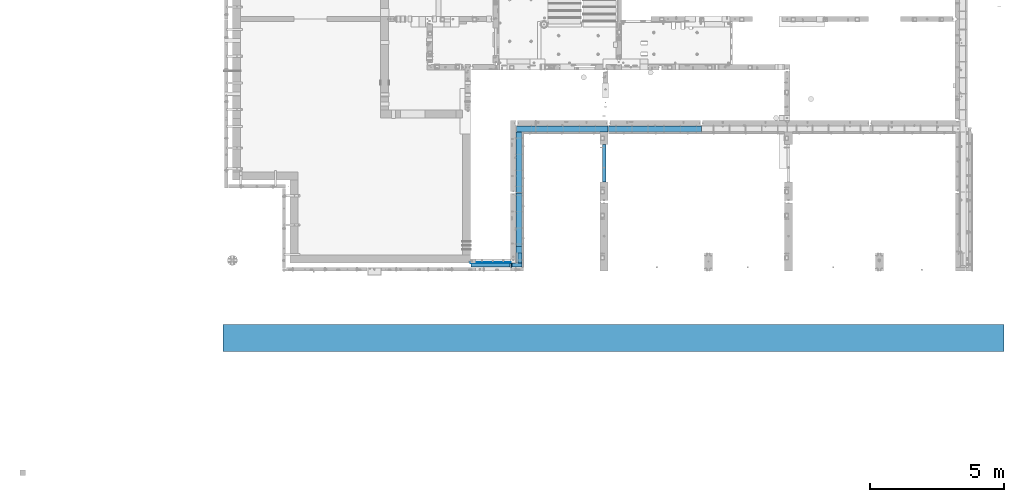
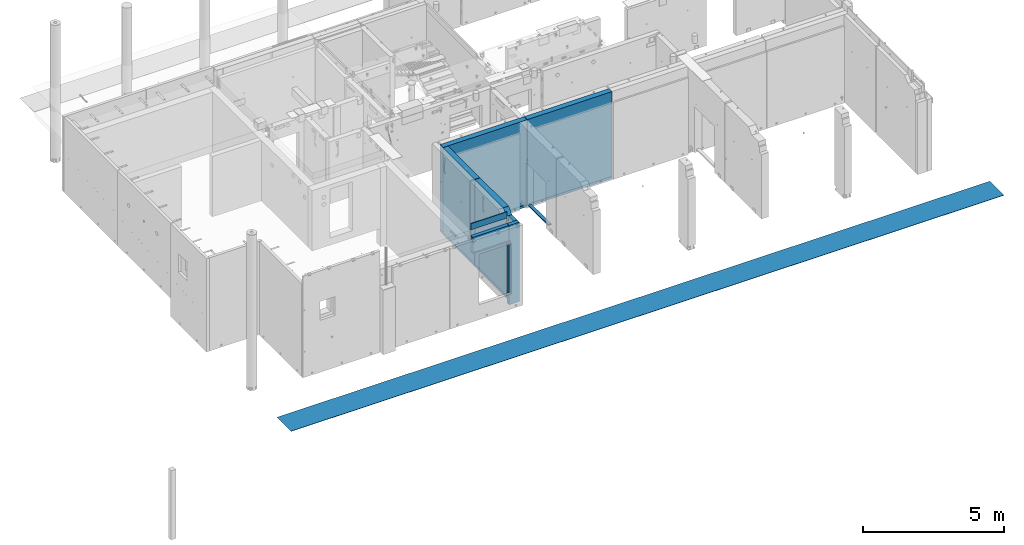
# One storey, part 79 of 264: 16 beams, 11 elements without a shape of their own.
"""IFC2X3 building model written with IfcOpenShell, lengths in millimetres."""

from ifc_helpers import new_model, si_unit, frame, origin_with_axes, place, context, subcontext, project, spatial, faceted_brep, material, type_object, element, aggregate, save


model = new_model("IFC2X3")

# Units and contexts
model_context = context("Model", 3, precision=1e-05, world=origin_with_axes())
body_context = subcontext(model_context, "Body", "Model", "MODEL_VIEW")
ifc_project = project(units=[si_unit("LENGTHUNIT", "METRE", prefix="MILLI"), si_unit("AREAUNIT", "SQUARE_METRE"), si_unit("VOLUMEUNIT", "CUBIC_METRE"), si_unit("MASSUNIT", "GRAM", prefix="KILO"), si_unit("TIMEUNIT", "SECOND"), si_unit("PLANEANGLEUNIT", "RADIAN"), si_unit("SOLIDANGLEUNIT", "STERADIAN"), si_unit("THERMODYNAMICTEMPERATUREUNIT", "DEGREE_CELSIUS"), si_unit("LUMINOUSINTENSITYUNIT", "LUMEN")], contexts=[model_context])

# Site, building, storey
site_placement = place(None, origin_with_axes())
site = spatial("IfcSite", under=ifc_project, at=site_placement, CompositionType="ELEMENT")
building_placement = place(site_placement, origin_with_axes())
building = spatial("IfcBuilding", under=site, at=building_placement, CompositionType="ELEMENT")
storey_placement = place(building_placement, origin_with_axes())
storey = spatial("IfcBuildingStorey", under=building, at=storey_placement, Name="K", CompositionType="ELEMENT", Elevation=0.0)

# Assembly, beam
assembly_1_placement = place(storey_placement, origin_with_axes())
assembly_1 = element("IfcElementAssembly", 1, at=assembly_1_placement, inside=storey, AssemblyPlace="NOTDEFINED", PredefinedType="REINFORCEMENT_UNIT")
ifc_material_1 = material(Name="TIMBER")
beam_type_1 = type_object("IfcBeamType", Name="50X150", PredefinedType="NOTDEFINED")
beam_1_placement = place(assembly_1_placement, frame((18244.999460885, 7774.99768910358, 80559.9999999994), z_axis=(0.0, 0.0, 1.0), x_axis=(-1.0, 3.00000001838171e-08, 0.0)))
beam_1 = element("IfcBeam", 2, at=beam_1_placement, type_object=beam_type_1, material=ifc_material_1, ObjectType="50X150", context=body_context, shape_type="Brep", body=[
    faceted_brep([(0.0, 75.0, -25.0), (1.81898940354586e-12, 75.0, 25.0), (1470.00000000023, 75.0, 25.0), (1470.00000000023, 75.0, -25.0), (1.81898940354586e-12, -75.0000000000009, 25.0), (1470.00000000023, -75.0, 25.0), (0.0, -75.0, -25.0), (1470.00000000023, -75.0, -25.0)], [[[0, 1, 2, 3]], [[1, 4, 5, 2]], [[4, 6, 7, 5]], [[6, 0, 3, 7]], [[5, 7, 3, 2]], [[6, 4, 1, 0]]]),
])

assembly_2_placement = place(storey_placement, origin_with_axes())
assembly_2 = element("IfcElementAssembly", 3, at=assembly_2_placement, inside=storey, AssemblyPlace="NOTDEFINED", PredefinedType="REINFORCEMENT_UNIT")
beam_2_placement = place(assembly_2_placement, frame((18285.0, 7770.0013793877, 80585.0), z_axis=(1.0, 0.0, 0.0), x_axis=(0.0, 0.0, -1.0)))
beam_2 = element("IfcBeam", 4, at=beam_2_placement, type_object=beam_type_1, material=ifc_material_1, ObjectType="50X150", context=body_context, shape_type="Brep", body=[
    faceted_brep([(0.0, 75.0, -25.0), (1.81898940354586e-12, 75.0, 25.0), (2285.0, 75.0, 25.0), (2285.0, 75.0, -25.0), (1.81898940354586e-12, -75.0000000000009, 25.0), (2285.0, -75.0, 25.0), (0.0, -75.0, -25.0), (2285.0, -75.0, -25.0)], [[[0, 1, 2, 3]], [[1, 4, 5, 2]], [[4, 6, 7, 5]], [[6, 0, 3, 7]], [[5, 7, 3, 2]], [[6, 4, 1, 0]]]),
])

assembly_3_placement = place(storey_placement, origin_with_axes())
assembly_3 = element("IfcElementAssembly", 5, at=assembly_3_placement, inside=storey, AssemblyPlace="NOTDEFINED", PredefinedType="REINFORCEMENT_UNIT")
ifc_material_2 = material(Name="TIMBER/PUU")
beam_type_2 = type_object("IfcBeamType", PredefinedType="NOTDEFINED")
beam_3_placement = place(assembly_3_placement, frame((21760.0, 12290.0, 78115.0), z_axis=(0.0, 0.0, 1.0), x_axis=(0.0, -1.0, 0.0)))
beam_3 = element("IfcBeam", 6, at=beam_3_placement, type_object=beam_type_2, material=ifc_material_2, context=body_context, shape_type="Brep", body=[
    faceted_brep([(0.0, 62.5, -25.0), (0.0, 62.5, 25.0), (1410.00023037194, 62.5, 25.0), (1410.00023037194, 62.5, -25.0), (0.0, -62.5, 25.0), (1410.00023037194, -62.5, 25.0), (0.0, -62.5, -25.0), (1410.00023037194, -62.5, -25.0)], [[[0, 1, 2, 3]], [[1, 4, 5, 2]], [[4, 6, 7, 5]], [[6, 0, 3, 7]], [[5, 7, 3, 2]], [[6, 4, 1, 0]]]),
])
aggregate(assembly_3, [beam_3])

# Beam
ifc_material_3 = material(Name="CONCRETE/C25/30")
beam_type_3 = type_object("IfcBeamType", PredefinedType="NOTDEFINED")
beam_4_placement = place(assembly_2_placement, frame((18570.0, 10480.0018965848, 77750.0), z_axis=(0.0, 0.0, 1.0), x_axis=(0.0, -1.0, 0.0)))
beam_4 = element("IfcBeam", 7, at=beam_4_placement, type_object=beam_type_3, material=ifc_material_3, context=body_context, shape_type="Brep", body=[
    faceted_brep([(-3.63797880709171e-12, 109.999999999996, -50.0), (-3.63797880709171e-12, 109.999999999996, 50.0), (2635.00189658477, 110.0, 50.0), (2635.00189658477, 110.0, -50.0), (-3.63797880709171e-12, -110.0, 50.0), (2635.00189658477, -110.0, 50.0), (-3.63797880709171e-12, -110.0, -50.0), (2635.00189658477, -110.0, -50.0)], [[[0, 1, 2, 3]], [[1, 4, 5, 2]], [[4, 6, 7, 5]], [[6, 0, 3, 7]], [[5, 7, 3, 2]], [[6, 4, 1, 0]]]),
])

# Assembly, beam
assembly_4_placement = place(storey_placement, origin_with_axes())
assembly_4 = element("IfcElementAssembly", 8, at=assembly_4_placement, inside=storey, AssemblyPlace="NOTDEFINED", PredefinedType="REINFORCEMENT_UNIT")
beam_5_placement = place(assembly_4_placement, frame((18570.0, 12755.0018965848, 77750.0), z_axis=(0.0, 0.0, 1.0), x_axis=(0.0, -1.0, 0.0)))
beam_5 = element("IfcBeam", 9, at=beam_5_placement, type_object=beam_type_3, material=ifc_material_3, context=body_context, shape_type="Brep", body=[
    faceted_brep([(-3.63797880709171e-12, 109.999999999996, -50.0), (-3.63797880709171e-12, 109.999999999996, 50.0), (2260.0, 110.0, 50.0), (2260.0, 110.0, -50.0), (-3.63797880709171e-12, -110.0, 50.0), (2260.0, -110.0, 50.0), (-3.63797880709171e-12, -110.0, -50.0), (2260.0, -110.0, -50.0)], [[[0, 1, 2, 3]], [[1, 4, 5, 2]], [[4, 6, 7, 5]], [[6, 0, 3, 7]], [[5, 7, 3, 2]], [[6, 4, 1, 0]]]),
])

assembly_5_placement = place(storey_placement, origin_with_axes())
assembly_5 = element("IfcElementAssembly", 10, at=assembly_5_placement, inside=storey, AssemblyPlace="NOTDEFINED", PredefinedType="REINFORCEMENT_UNIT")
beam_6_placement = place(assembly_5_placement, frame((21910.0, 12870.0018965848, 77750.0), z_axis=(0.0, 0.0, 1.0), x_axis=(-1.0, 3.00000001838171e-08, 0.0)))
beam_6 = element("IfcBeam", 11, at=beam_6_placement, type_object=beam_type_3, material=ifc_material_3, context=body_context, shape_type="Brep", body=[
    faceted_brep([(-3.63797880709171e-12, 109.999999999996, -50.0), (-3.63797880709171e-12, 109.999999999996, 50.0), (3435.0, 110.0, 50.0), (3435.0, 110.0, -50.0), (-3.63797880709171e-12, -110.0, 50.0), (3435.0, -110.0, 50.0), (-3.63797880709171e-12, -110.0, -50.0), (3435.0, -110.0, -50.0)], [[[0, 1, 2, 3]], [[1, 4, 5, 2]], [[4, 6, 7, 5]], [[6, 0, 3, 7]], [[5, 7, 3, 2]], [[6, 4, 1, 0]]]),
])

assembly_6_placement = place(storey_placement, origin_with_axes())
assembly_6 = element("IfcElementAssembly", 12, at=assembly_6_placement, inside=storey, AssemblyPlace="NOTDEFINED", PredefinedType="REINFORCEMENT_UNIT")
beam_7_placement = place(assembly_6_placement, frame((25395.0012286569, 12870.0018965848, 77750.0), z_axis=(0.0, 0.0, 1.0), x_axis=(-1.0, 3.00000001838171e-08, 0.0)))
beam_7 = element("IfcBeam", 13, at=beam_7_placement, type_object=beam_type_3, material=ifc_material_3, context=body_context, shape_type="Brep", body=[
    faceted_brep([(-3.63797880709171e-12, 109.999999999996, -50.0), (-3.63797880709171e-12, 109.999999999996, 50.0), (3470.00122865687, 110.0, 50.0), (3470.00122865687, 110.0, -50.0), (-3.63797880709171e-12, -110.0, 50.0), (3470.00122865687, -110.0, 50.0), (-3.63797880709171e-12, -110.0, -50.0), (3470.00122865687, -110.0, -50.0)], [[[0, 1, 2, 3]], [[1, 4, 5, 2]], [[4, 6, 7, 5]], [[6, 0, 3, 7]], [[5, 7, 3, 2]], [[6, 4, 1, 0]]]),
])

# Beam
ifc_material_4 = material(Name="CONCRETE/C30/37")
beam_type_4 = type_object("IfcBeamType", Name="270X30", PredefinedType="NOTDEFINED")
beam_8_placement = place(assembly_1_placement, frame((18265.0024573138, 7865.00189658478, 81605.0), z_axis=(0.0, 0.0, -1.0), x_axis=(-1.0, 3.00000001838171e-08, 0.0)))
beam_8 = element("IfcBeam", 14, at=beam_8_placement, type_object=beam_type_4, material=ifc_material_4, ObjectType="270X30", context=body_context, shape_type="Brep", body=[
    faceted_brep([(0.0, 15.0, -135.0), (0.0, 15.0, 135.0), (1490.0, 15.0, 135.0), (1490.0, 15.0, -135.0), (0.0, -15.0, 135.0), (1490.0, -15.0, 135.0), (0.0, -15.0, -135.0), (1490.0, -15.0, -135.0)], [[[0, 1, 2, 3]], [[1, 4, 5, 2]], [[4, 6, 7, 5]], [[6, 0, 3, 7]], [[5, 7, 3, 2]], [[6, 4, 1, 0]]]),
])

ifc_material_5 = material(Name="SPU")
beam_type_5 = type_object("IfcBeamType", PredefinedType="NOTDEFINED")
beam_9_placement = place(assembly_1_placement, frame((18245.0001315568, 7775.0, 80887.5), z_axis=(0.0, 0.0, 1.0), x_axis=(-1.0, 3.00000001838171e-08, 0.0)))
beam_9 = element("IfcBeam", 15, at=beam_9_placement, type_object=beam_type_5, material=ifc_material_5, context=body_context, shape_type="Brep", body=[
    faceted_brep([(0.0, 75.0, -352.5), (0.0, 75.0, 352.5), (1470.00067067121, 75.0, 352.5), (1470.00067067121, 75.0, -352.5), (0.0, -75.0, 352.5), (1470.00067067121, -75.0, 352.5), (0.0, -75.0, -352.5), (1470.00067067121, -75.0, -352.5)], [[[0, 1, 2, 3]], [[1, 4, 5, 2]], [[4, 6, 7, 5]], [[6, 0, 3, 7]], [[5, 7, 3, 2]], [[6, 4, 1, 0]]]),
])

aggregate(assembly_1, [beam_8, beam_9, beam_1])

beam_type_6 = type_object("IfcBeamType", PredefinedType="NOTDEFINED")
beam_10_placement = place(assembly_2_placement, frame((18259.999661324, 7770.00189658558, 79520.0), z_axis=(0.0, 0.0, 1.0), x_axis=(0.999999999989803, -4.51600000073318e-06, 0.0)))
beam_10 = element("IfcBeam", 16, at=beam_10_placement, type_object=beam_type_6, material=ifc_material_5, context=body_context, shape_type="Brep", body=[
    faceted_brep([(0.0, 75.0, -1720.0), (0.0, 75.0, 1720.0), (420.000000005264, 75.0, 1720.0), (420.000000005264, 75.0, -1720.0), (3.63797880709171e-12, -74.9999999999991, 1720.0), (420.000000005264, -74.9999999999991, 1720.0), (3.63797880709171e-12, -74.9999999999991, -1720.0), (420.000000005264, -74.9999999999991, -1720.0)], [[[0, 1, 2, 3]], [[1, 4, 5, 2]], [[4, 6, 7, 5]], [[6, 0, 3, 7]], [[5, 7, 3, 2]], [[6, 4, 1, 0]]]),
])

beam_11_placement = place(assembly_2_placement, frame((18605.0, 8230.00189658477, 79520.0), z_axis=(0.0, 0.0, 1.0), x_axis=(0.0, -1.0, 0.0)))
beam_11 = element("IfcBeam", 17, at=beam_11_placement, type_object=beam_type_6, material=ifc_material_5, context=body_context, shape_type="Brep", body=[
    faceted_brep([(0.0, 75.0, -1720.0), (0.0, 75.0, 1720.0), (385.001896584767, 75.0, 1720.0), (385.001896584767, 75.0, -1720.0), (3.63797880709171e-12, -74.9999999999991, 1720.0), (385.001896584767, -75.0, 1720.0), (3.63797880709171e-12, -74.9999999999991, -1720.0), (385.001896584767, -75.0, -1720.0)], [[[0, 1, 2, 3]], [[1, 4, 5, 2]], [[4, 6, 7, 5]], [[6, 0, 3, 7]], [[5, 7, 3, 2]], [[6, 4, 1, 0]]]),
])

# Assembly, beam
assembly_7_placement = place(storey_placement, origin_with_axes())
assembly_7 = element("IfcElementAssembly", 18, at=assembly_7_placement, inside=storey, Name="Steel Assembly", AssemblyPlace="NOTDEFINED", PredefinedType="NOTDEFINED")
ifc_material_6 = material()
beam_type_7 = type_object("IfcBeamType", PredefinedType="NOTDEFINED")
beam_12_placement = place(assembly_7_placement, frame((36724.9992355705, 5047.50003665686, 77992.5), z_axis=(0.0, -1.0, 0.0), x_axis=(-1.0, 3.00000001838171e-08, 0.0)))
beam_12 = element("IfcBeam", 19, at=beam_12_placement, type_object=beam_type_7, material=ifc_material_6, context=body_context, shape_type="Brep", body=[
    faceted_brep([(0.0, 7.5, -500.0), (0.0, 7.5, 500.0), (29219.9999999995, 7.5, 500.0), (29219.9999999995, 7.5, -500.0), (0.0, -7.5, 500.0), (29219.9999999995, -7.5, 500.0), (0.0, -7.5, -500.0), (29219.9999999995, -7.5, -500.0)], [[[0, 1, 2, 3]], [[1, 4, 5, 2]], [[4, 6, 7, 5]], [[6, 0, 3, 7]], [[5, 7, 3, 2]], [[6, 4, 1, 0]]]),
])
aggregate(assembly_7, [beam_12])

# Assembly
assembly_8_placement = place(assembly_2_placement, origin_with_axes())
assembly_8 = element("IfcElementAssembly", 20, at=assembly_8_placement, Name="Steel Assembly", AssemblyPlace="NOTDEFINED", PredefinedType="NOTDEFINED")

aggregate(assembly_2, [beam_2, beam_10, beam_11, beam_4, assembly_8])

# Beam
ifc_material_7 = material(Name="EPS100")
beam_type_8 = type_object("IfcBeamType", PredefinedType="NOTDEFINED")
beam_13_placement = place(assembly_8_placement, frame((18570.0, 10480.0018965848, 79635.0), z_axis=(0.0, 0.0, 1.0), x_axis=(0.0, -1.0, 0.0)))
beam_13 = element("IfcBeam", 21, at=beam_13_placement, type_object=beam_type_8, material=ifc_material_7, context=body_context, shape_type="Brep", body=[
    faceted_brep([(2019.67157395192, 110.0, 1835.0), (2019.67157395192, -110.0, 1835.0), (2250.00189658477, -110.0, 1605.0), (2250.00189658477, 110.0, 1605.0), (0.0, -110.0, -1835.0), (0.0, 110.0, -1835.0), (2250.00189658477, 110.0, -1835.0), (2250.00189658477, -110.0, -1835.0), (0.0, -110.0, 1835.0), (0.0, 110.0, 1835.0)], [[[0, 1, 2, 3]], [[4, 5, 6, 7]], [[4, 8, 9, 5]], [[6, 5, 9, 0, 3]], [[7, 6, 3, 2]], [[8, 4, 7, 2, 1]], [[9, 8, 1, 0]]]),
])

aggregate(assembly_8, [beam_13])

# Assembly
assembly_9_placement = place(assembly_4_placement, origin_with_axes())
assembly_9 = element("IfcElementAssembly", 22, at=assembly_9_placement, Name="Steel Assembly", AssemblyPlace="NOTDEFINED", PredefinedType="NOTDEFINED")

aggregate(assembly_4, [beam_5, assembly_9])

# Beam
beam_14_placement = place(assembly_9_placement, frame((18570.0, 12755.0018965848, 79635.0), z_axis=(0.0, 0.0, 1.0), x_axis=(0.0, -1.0, 0.0)))
beam_14 = element("IfcBeam", 23, at=beam_14_placement, type_object=beam_type_8, material=ifc_material_7, context=body_context, shape_type="Brep", body=[
    faceted_brep([(0.0, 110.0, -1835.0), (0.0, 110.0, 1835.0), (2260.0, 110.0, 1835.0), (2260.0, 110.0, -1835.0), (0.0, -110.0, 1835.0), (2260.0, -110.0, 1835.0), (0.0, -110.0, -1835.0), (2260.0, -110.0, -1835.0)], [[[0, 1, 2, 3]], [[1, 4, 5, 2]], [[4, 6, 7, 5]], [[6, 0, 3, 7]], [[5, 7, 3, 2]], [[6, 4, 1, 0]]]),
])

aggregate(assembly_9, [beam_14])

# Assembly
assembly_10_placement = place(assembly_5_placement, origin_with_axes())
assembly_10 = element("IfcElementAssembly", 24, at=assembly_10_placement, Name="Steel Assembly", AssemblyPlace="NOTDEFINED", PredefinedType="NOTDEFINED")

aggregate(assembly_5, [assembly_10, beam_6])

# Beam
beam_15_placement = place(assembly_10_placement, frame((21910.0, 12870.0018965848, 79635.0), z_axis=(0.0, 0.0, 1.0), x_axis=(-1.0, 3.00000001838171e-08, 0.0)))
beam_15 = element("IfcBeam", 25, at=beam_15_placement, type_object=beam_type_8, material=ifc_material_7, context=body_context, shape_type="Brep", body=[
    faceted_brep([(2686.45898241561, -110.0, -265.432914190867), (2686.45898241561, 110.0, -265.432914190867), (2691.87830119873, 110.0, -257.322330470342), (2691.87830119873, -110.0, -257.322330470342), (2699.98888491927, 110.0, -251.903011687216), (2699.98888491927, -110.0, -251.903011687216), (2709.5559707284, 110.0, -250.0), (2709.5559707284, -110.0, -250.0), (2719.12305653753, 110.0, -251.903011687216), (2719.12305653753, -110.0, -251.903011687216), (2727.23364025806, 110.0, -257.322330470342), (2727.23364025806, -110.0, -257.322330470342), (2732.65295904118, 110.0, -265.432914190867), (2732.65295904118, -110.0, -265.432914190867), (2734.5559707284, 110.0, -275.0), (2734.5559707284, -110.0, -275.0), (2732.65295904118, 110.0, -284.567085809133), (2732.65295904118, -110.0, -284.567085809133), (2727.23364025806, 110.0, -292.677669529658), (2727.23364025806, -110.0, -292.677669529658), (2719.12305653753, 110.0, -298.096988312784), (2719.12305653753, -110.0, -298.096988312784), (2709.5559707284, 110.0, -300.0), (2709.5559707284, -110.0, -300.0), (2699.98888491927, 110.0, -298.096988312784), (2699.98888491927, -110.0, -298.096988312784), (2691.87830119873, 110.0, -292.677669529658), (2691.87830119873, -110.0, -292.677669529658), (2686.45898241561, 110.0, -284.567085809133), (2686.45898241561, -110.0, -284.567085809133), (2684.5559707284, 110.0, -275.0), (2684.5559707284, -110.0, -275.0), (0.0, -110.0, 1835.0), (0.0, -110.0, -1835.0), (3435.0, -110.0, -1835.0), (3435.0, -110.0, 1835.0), (0.0, 110.0, 1835.0), (3435.0, 110.0, 1835.0), (0.0, 110.0, -1835.0), (3435.0, 110.0, -1835.0)], [[[0, 1, 2, 3]], [[3, 2, 4, 5]], [[5, 4, 6, 7]], [[7, 6, 8, 9]], [[9, 8, 10, 11]], [[11, 10, 12, 13]], [[13, 12, 14, 15]], [[15, 14, 16, 17]], [[17, 16, 18, 19]], [[19, 18, 20, 21]], [[21, 20, 22, 23]], [[23, 22, 24, 25]], [[25, 24, 26, 27]], [[27, 26, 28, 29]], [[29, 28, 30, 31]], [[31, 30, 1, 0]], [[32, 33, 34, 35], [3, 5, 7, 9, 11, 13, 15, 17, 19, 21, 23, 25, 27, 29, 31, 0]], [[36, 32, 35, 37]], [[33, 32, 36, 38]], [[33, 38, 39, 34]], [[35, 34, 39, 37]], [[38, 36, 37, 39], [26, 24, 22, 20, 18, 16, 14, 12, 10, 8, 6, 4, 2, 1, 30, 28]]]),
])

aggregate(assembly_10, [beam_15])

# Assembly
assembly_11_placement = place(assembly_6_placement, origin_with_axes())
assembly_11 = element("IfcElementAssembly", 26, at=assembly_11_placement, Name="Steel Assembly", AssemblyPlace="NOTDEFINED", PredefinedType="NOTDEFINED")

aggregate(assembly_6, [assembly_11, beam_7])

# Beam
beam_16_placement = place(assembly_11_placement, frame((25395.0012286569, 12870.0018965848, 79635.0), z_axis=(0.0, 0.0, 1.0), x_axis=(-1.0, 3.00000001838171e-08, 0.0)))
beam_16 = element("IfcBeam", 27, at=beam_16_placement, type_object=beam_type_8, material=ifc_material_7, context=body_context, shape_type="Brep", body=[
    faceted_brep([(0.0, 110.0, -1835.0), (0.0, 110.0, 1835.0), (3470.00122865687, 110.0, 1835.0), (3470.00122865687, 110.0, -1835.0), (0.0, -110.0, 1835.0), (3470.00122865687, -110.0, 1835.0), (0.0, -110.0, -1835.0), (3470.00122865687, -110.0, -1835.0)], [[[0, 1, 2, 3]], [[1, 4, 5, 2]], [[4, 6, 7, 5]], [[6, 0, 3, 7]], [[5, 7, 3, 2]], [[6, 4, 1, 0]]]),
])

aggregate(assembly_11, [beam_16])

save(model, "model.ifc")
